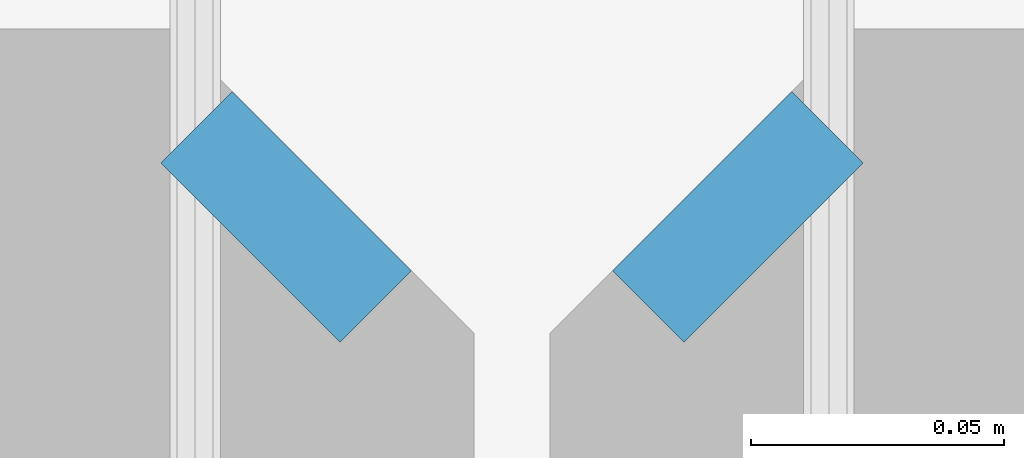
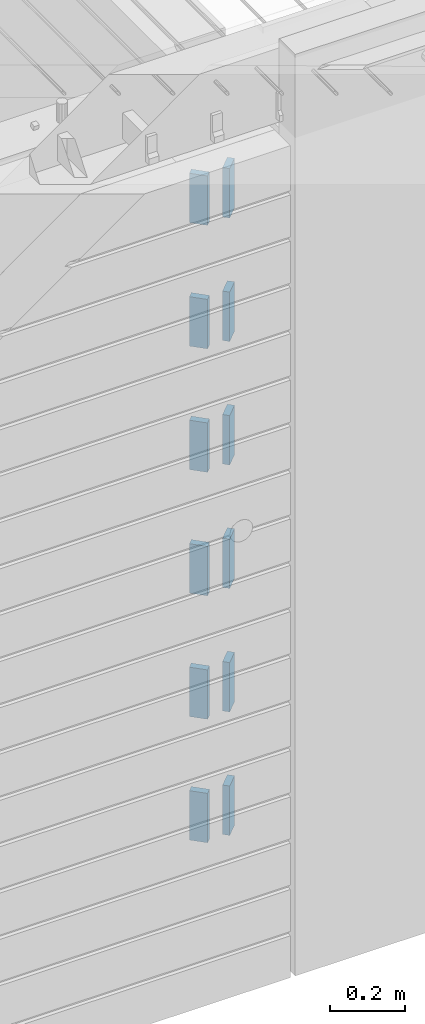
# One storey, part 214 of 349: 12 plates, 14 elements without a shape of their own.
"""IFC2X3 building model written with IfcOpenShell, lengths in millimetres."""

from ifc_helpers import new_model, si_unit, frame, origin_with_axes, place, context, subcontext, project, spatial, faceted_brep, material, type_object, element, aggregate, save


model = new_model("IFC2X3")

# Units and contexts
model_context = context("Model", 3, precision=1e-05, world=origin_with_axes())
body_context = subcontext(model_context, "Body", "Model", "MODEL_VIEW")
ifc_project = project(units=[si_unit("LENGTHUNIT", "METRE", prefix="MILLI"), si_unit("AREAUNIT", "SQUARE_METRE"), si_unit("VOLUMEUNIT", "CUBIC_METRE"), si_unit("MASSUNIT", "GRAM", prefix="KILO"), si_unit("TIMEUNIT", "SECOND"), si_unit("PLANEANGLEUNIT", "RADIAN"), si_unit("SOLIDANGLEUNIT", "STERADIAN"), si_unit("THERMODYNAMICTEMPERATUREUNIT", "DEGREE_CELSIUS"), si_unit("LUMINOUSINTENSITYUNIT", "LUMEN")], contexts=[model_context])

# Site, building, storey
site_placement = place(None, origin_with_axes())
site = spatial("IfcSite", under=ifc_project, at=site_placement, CompositionType="ELEMENT")
building_placement = place(site_placement, origin_with_axes())
building = spatial("IfcBuilding", under=site, at=building_placement, CompositionType="ELEMENT")
storey_placement = place(building_placement, origin_with_axes())
storey = spatial("IfcBuildingStorey", under=building, at=storey_placement, Name="4", CompositionType="ELEMENT", Elevation=0.0)

# Assemblies, plates
assembly_1_placement = place(storey_placement, origin_with_axes())
assembly_1 = element("IfcElementAssembly", 1, at=assembly_1_placement, inside=storey, AssemblyPlace="NOTDEFINED", PredefinedType="REINFORCEMENT_UNIT")
assembly_2_placement = place(assembly_1_placement, origin_with_axes())
assembly_2 = element("IfcElementAssembly", 2, at=assembly_2_placement, Name="Steel Assembly", AssemblyPlace="NOTDEFINED", PredefinedType="RIGID_FRAME")
ifc_material = material(Name="STEEL/Steel_Undefined")
plate_type = type_object("IfcPlateType", PredefinedType="NOTDEFINED")
plate_1_placement = place(assembly_2_placement, frame((28641.4644660941, 7938.1801948466, 93042.5), z_axis=(-0.707106781186547, 0.707106781186548, 0.0), x_axis=(0.707106781186557, 0.707106781186538, 0.0)))
plate_1 = element("IfcPlate", 3, at=plate_1_placement, type_object=plate_type, material=ifc_material, Name="VL_080", context=body_context, shape_type="Brep", body=[
    faceted_brep([(0.0, -80.0, 0.0), (0.0, -80.0, 20.0), (0.0, 80.0, 20.0), (0.0, 80.0, 0.0), (50.0, -80.0, 20.0), (50.0, 80.0, 20.0), (50.0, -80.0, 0.0), (50.0, 80.0, 0.0)], [[[0, 1, 2, 3]], [[1, 4, 5, 2]], [[4, 6, 7, 5]], [[6, 0, 3, 7]], [[5, 7, 3, 2]], [[6, 4, 1, 0]]]),
])
aggregate(assembly_2, [plate_1])
assembly_3_placement = place(assembly_1_placement, origin_with_axes())
assembly_3 = element("IfcElementAssembly", 4, at=assembly_3_placement, Name="Steel Assembly", AssemblyPlace="NOTDEFINED", PredefinedType="RIGID_FRAME")
plate_2_placement = place(assembly_3_placement, frame((28641.4644660941, 7938.1801948466, 92642.5), z_axis=(-0.707106781186547, 0.707106781186548, 0.0), x_axis=(0.707106781186557, 0.707106781186538, 0.0)))
plate_2 = element("IfcPlate", 5, at=plate_2_placement, type_object=plate_type, material=ifc_material, Name="VL_080", context=body_context, shape_type="Brep", body=[
    faceted_brep([(0.0, -80.0, 0.0), (0.0, -80.0, 20.0), (0.0, 80.0, 20.0), (0.0, 80.0, 0.0), (50.0, -80.0, 20.0), (50.0, 80.0, 20.0), (50.0, -80.0, 0.0), (50.0, 80.0, 0.0)], [[[0, 1, 2, 3]], [[1, 4, 5, 2]], [[4, 6, 7, 5]], [[6, 0, 3, 7]], [[5, 7, 3, 2]], [[6, 4, 1, 0]]]),
])
aggregate(assembly_3, [plate_2])
assembly_4_placement = place(assembly_1_placement, origin_with_axes())
assembly_4 = element("IfcElementAssembly", 6, at=assembly_4_placement, Name="Steel Assembly", AssemblyPlace="NOTDEFINED", PredefinedType="RIGID_FRAME")
plate_3_placement = place(assembly_4_placement, frame((28641.4644660941, 7938.1801948466, 92242.5), z_axis=(-0.707106781186547, 0.707106781186548, 0.0), x_axis=(0.707106781186557, 0.707106781186538, 0.0)))
plate_3 = element("IfcPlate", 7, at=plate_3_placement, type_object=plate_type, material=ifc_material, Name="VL_080", context=body_context, shape_type="Brep", body=[
    faceted_brep([(0.0, -80.0, 0.0), (0.0, -80.0, 20.0), (0.0, 80.0, 20.0), (0.0, 80.0, 0.0), (50.0, -80.0, 20.0), (50.0, 80.0, 20.0), (50.0, -80.0, 0.0), (50.0, 80.0, 0.0)], [[[0, 1, 2, 3]], [[1, 4, 5, 2]], [[4, 6, 7, 5]], [[6, 0, 3, 7]], [[5, 7, 3, 2]], [[6, 4, 1, 0]]]),
])
aggregate(assembly_4, [plate_3])

assembly_5_placement = place(storey_placement, origin_with_axes())
assembly_5 = element("IfcElementAssembly", 8, at=assembly_5_placement, inside=storey, AssemblyPlace="NOTDEFINED", PredefinedType="REINFORCEMENT_UNIT")
assembly_6_placement = place(assembly_5_placement, origin_with_axes())
assembly_6 = element("IfcElementAssembly", 9, at=assembly_6_placement, Name="Steel Assembly", AssemblyPlace="NOTDEFINED", PredefinedType="RIGID_FRAME")
plate_4_placement = place(assembly_6_placement, frame((28538.1801948466, 7973.53553390593, 93042.5), z_axis=(0.707106781186557, 0.707106781186538, 0.0), x_axis=(0.707106781186557, -0.707106781186538, 0.0)))
plate_4 = element("IfcPlate", 10, at=plate_4_placement, type_object=plate_type, material=ifc_material, Name="VL_080", context=body_context, shape_type="Brep", body=[
    faceted_brep([(0.0, -80.0, 0.0), (0.0, -80.0, 20.0), (0.0, 80.0, 20.0), (0.0, 80.0, 0.0), (50.0, -80.0, 20.0), (50.0, 80.0, 20.0), (50.0, -80.0, 0.0), (50.0, 80.0, 0.0)], [[[0, 1, 2, 3]], [[1, 4, 5, 2]], [[4, 6, 7, 5]], [[6, 0, 3, 7]], [[5, 7, 3, 2]], [[6, 4, 1, 0]]]),
])
aggregate(assembly_6, [plate_4])
assembly_7_placement = place(assembly_5_placement, origin_with_axes())
assembly_7 = element("IfcElementAssembly", 11, at=assembly_7_placement, Name="Steel Assembly", AssemblyPlace="NOTDEFINED", PredefinedType="RIGID_FRAME")
plate_5_placement = place(assembly_7_placement, frame((28538.1801948466, 7973.53553390593, 92642.5), z_axis=(0.707106781186557, 0.707106781186538, 0.0), x_axis=(0.707106781186557, -0.707106781186538, 0.0)))
plate_5 = element("IfcPlate", 12, at=plate_5_placement, type_object=plate_type, material=ifc_material, Name="VL_080", context=body_context, shape_type="Brep", body=[
    faceted_brep([(0.0, -80.0, 0.0), (0.0, -80.0, 20.0), (0.0, 80.0, 20.0), (0.0, 80.0, 0.0), (50.0, -80.0, 20.0), (50.0, 80.0, 20.0), (50.0, -80.0, 0.0), (50.0, 80.0, 0.0)], [[[0, 1, 2, 3]], [[1, 4, 5, 2]], [[4, 6, 7, 5]], [[6, 0, 3, 7]], [[5, 7, 3, 2]], [[6, 4, 1, 0]]]),
])
aggregate(assembly_7, [plate_5])
assembly_8_placement = place(assembly_5_placement, origin_with_axes())
assembly_8 = element("IfcElementAssembly", 13, at=assembly_8_placement, Name="Steel Assembly", AssemblyPlace="NOTDEFINED", PredefinedType="RIGID_FRAME")
plate_6_placement = place(assembly_8_placement, frame((28538.1801948466, 7973.53553390593, 92242.5), z_axis=(0.707106781186557, 0.707106781186538, 0.0), x_axis=(0.707106781186557, -0.707106781186538, 0.0)))
plate_6 = element("IfcPlate", 14, at=plate_6_placement, type_object=plate_type, material=ifc_material, Name="VL_080", context=body_context, shape_type="Brep", body=[
    faceted_brep([(0.0, -80.0, 0.0), (0.0, -80.0, 20.0), (0.0, 80.0, 20.0), (0.0, 80.0, 0.0), (50.0, -80.0, 20.0), (50.0, 80.0, 20.0), (50.0, -80.0, 0.0), (50.0, 80.0, 0.0)], [[[0, 1, 2, 3]], [[1, 4, 5, 2]], [[4, 6, 7, 5]], [[6, 0, 3, 7]], [[5, 7, 3, 2]], [[6, 4, 1, 0]]]),
])
aggregate(assembly_8, [plate_6])
assembly_9_placement = place(assembly_5_placement, origin_with_axes())
assembly_9 = element("IfcElementAssembly", 15, at=assembly_9_placement, Name="Steel Assembly", AssemblyPlace="NOTDEFINED", PredefinedType="RIGID_FRAME")
plate_7_placement = place(assembly_9_placement, frame((28538.1801948466, 7973.53553390592, 91842.5), z_axis=(0.707106781186557, 0.707106781186538, 0.0), x_axis=(0.707106781186557, -0.707106781186538, 0.0)))
plate_7 = element("IfcPlate", 16, at=plate_7_placement, type_object=plate_type, material=ifc_material, Name="VL_080", context=body_context, shape_type="Brep", body=[
    faceted_brep([(0.0, -80.0, 0.0), (0.0, -80.0, 20.0), (0.0, 80.0, 20.0), (0.0, 80.0, 0.0), (50.0, -80.0, 20.0), (50.0, 80.0, 20.0), (50.0, -80.0, 0.0), (50.0, 80.0, 0.0)], [[[0, 1, 2, 3]], [[1, 4, 5, 2]], [[4, 6, 7, 5]], [[6, 0, 3, 7]], [[5, 7, 3, 2]], [[6, 4, 1, 0]]]),
])
aggregate(assembly_9, [plate_7])
assembly_10_placement = place(assembly_5_placement, origin_with_axes())
assembly_10 = element("IfcElementAssembly", 17, at=assembly_10_placement, Name="Steel Assembly", AssemblyPlace="NOTDEFINED", PredefinedType="RIGID_FRAME")
plate_8_placement = place(assembly_10_placement, frame((28538.1801948466, 7973.53553390591, 91442.5), z_axis=(0.707106781186557, 0.707106781186538, 0.0), x_axis=(0.707106781186557, -0.707106781186538, 0.0)))
plate_8 = element("IfcPlate", 18, at=plate_8_placement, type_object=plate_type, material=ifc_material, Name="VL_080", context=body_context, shape_type="Brep", body=[
    faceted_brep([(0.0, -80.0, 0.0), (0.0, -80.0, 20.0), (0.0, 80.0, 20.0), (0.0, 80.0, 0.0), (50.0, -80.0, 20.0), (50.0, 80.0, 20.0), (50.0, -80.0, 0.0), (50.0, 80.0, 0.0)], [[[0, 1, 2, 3]], [[1, 4, 5, 2]], [[4, 6, 7, 5]], [[6, 0, 3, 7]], [[5, 7, 3, 2]], [[6, 4, 1, 0]]]),
])
aggregate(assembly_10, [plate_8])
assembly_11_placement = place(assembly_5_placement, origin_with_axes())
assembly_11 = element("IfcElementAssembly", 19, at=assembly_11_placement, Name="Steel Assembly", AssemblyPlace="NOTDEFINED", PredefinedType="RIGID_FRAME")
aggregate(assembly_5, [assembly_6, assembly_7, assembly_8, assembly_9, assembly_10, assembly_11])
plate_9_placement = place(assembly_11_placement, frame((28538.1801948466, 7973.53553390592, 91042.5), z_axis=(0.707106781186557, 0.707106781186538, 0.0), x_axis=(0.707106781186557, -0.707106781186538, 0.0)))
plate_9 = element("IfcPlate", 20, at=plate_9_placement, type_object=plate_type, material=ifc_material, Name="VL_080", context=body_context, shape_type="Brep", body=[
    faceted_brep([(0.0, -80.0, 0.0), (0.0, -80.0, 20.0), (0.0, 80.0, 20.0), (0.0, 80.0, 0.0), (50.0, -80.0, 20.0), (50.0, 80.0, 20.0), (50.0, -80.0, 0.0), (50.0, 80.0, 0.0)], [[[0, 1, 2, 3]], [[1, 4, 5, 2]], [[4, 6, 7, 5]], [[6, 0, 3, 7]], [[5, 7, 3, 2]], [[6, 4, 1, 0]]]),
])
aggregate(assembly_11, [plate_9])

# Assembly, plate
assembly_12_placement = place(assembly_1_placement, origin_with_axes())
assembly_12 = element("IfcElementAssembly", 21, at=assembly_12_placement, Name="Steel Assembly", AssemblyPlace="NOTDEFINED", PredefinedType="RIGID_FRAME")
plate_10_placement = place(assembly_12_placement, frame((28641.4644660941, 7938.18019484659, 91842.5), z_axis=(-0.707106781186547, 0.707106781186548, 0.0), x_axis=(0.707106781186557, 0.707106781186538, 0.0)))
plate_10 = element("IfcPlate", 22, at=plate_10_placement, type_object=plate_type, material=ifc_material, Name="VL_080", context=body_context, shape_type="Brep", body=[
    faceted_brep([(0.0, -80.0, 0.0), (0.0, -80.0, 20.0), (0.0, 80.0, 20.0), (0.0, 80.0, 0.0), (50.0, -80.0, 20.0), (50.0, 80.0, 20.0), (50.0, -80.0, 0.0), (50.0, 80.0, 0.0)], [[[0, 1, 2, 3]], [[1, 4, 5, 2]], [[4, 6, 7, 5]], [[6, 0, 3, 7]], [[5, 7, 3, 2]], [[6, 4, 1, 0]]]),
])
aggregate(assembly_12, [plate_10])

assembly_13_placement = place(assembly_1_placement, origin_with_axes())
assembly_13 = element("IfcElementAssembly", 23, at=assembly_13_placement, Name="Steel Assembly", AssemblyPlace="NOTDEFINED", PredefinedType="RIGID_FRAME")
plate_11_placement = place(assembly_13_placement, frame((28641.4644660941, 7938.1801948466, 91442.5), z_axis=(-0.707106781186547, 0.707106781186548, 0.0), x_axis=(0.707106781186557, 0.707106781186538, 0.0)))
plate_11 = element("IfcPlate", 24, at=plate_11_placement, type_object=plate_type, material=ifc_material, Name="VL_080", context=body_context, shape_type="Brep", body=[
    faceted_brep([(0.0, -80.0, 0.0), (0.0, -80.0, 20.0), (0.0, 80.0, 20.0), (0.0, 80.0, 0.0), (50.0, -80.0, 20.0), (50.0, 80.0, 20.0), (50.0, -80.0, 0.0), (50.0, 80.0, 0.0)], [[[0, 1, 2, 3]], [[1, 4, 5, 2]], [[4, 6, 7, 5]], [[6, 0, 3, 7]], [[5, 7, 3, 2]], [[6, 4, 1, 0]]]),
])
aggregate(assembly_13, [plate_11])

# Assembly
assembly_14_placement = place(assembly_1_placement, origin_with_axes())
assembly_14 = element("IfcElementAssembly", 25, at=assembly_14_placement, Name="Steel Assembly", AssemblyPlace="NOTDEFINED", PredefinedType="RIGID_FRAME")

aggregate(assembly_1, [assembly_2, assembly_3, assembly_4, assembly_12, assembly_13, assembly_14])

# Plate
plate_12_placement = place(assembly_14_placement, frame((28641.4644660941, 7938.1801948466, 91042.5), z_axis=(-0.707106781186547, 0.707106781186548, 0.0), x_axis=(0.707106781186557, 0.707106781186538, 0.0)))
plate_12 = element("IfcPlate", 26, at=plate_12_placement, type_object=plate_type, material=ifc_material, Name="VL_080", context=body_context, shape_type="Brep", body=[
    faceted_brep([(0.0, -80.0, 0.0), (0.0, -80.0, 20.0), (0.0, 80.0, 20.0), (0.0, 80.0, 0.0), (50.0, -80.0, 20.0), (50.0, 80.0, 20.0), (50.0, -80.0, 0.0), (50.0, 80.0, 0.0)], [[[0, 1, 2, 3]], [[1, 4, 5, 2]], [[4, 6, 7, 5]], [[6, 0, 3, 7]], [[5, 7, 3, 2]], [[6, 4, 1, 0]]]),
])

aggregate(assembly_14, [plate_12])

save(model, "model.ifc")
